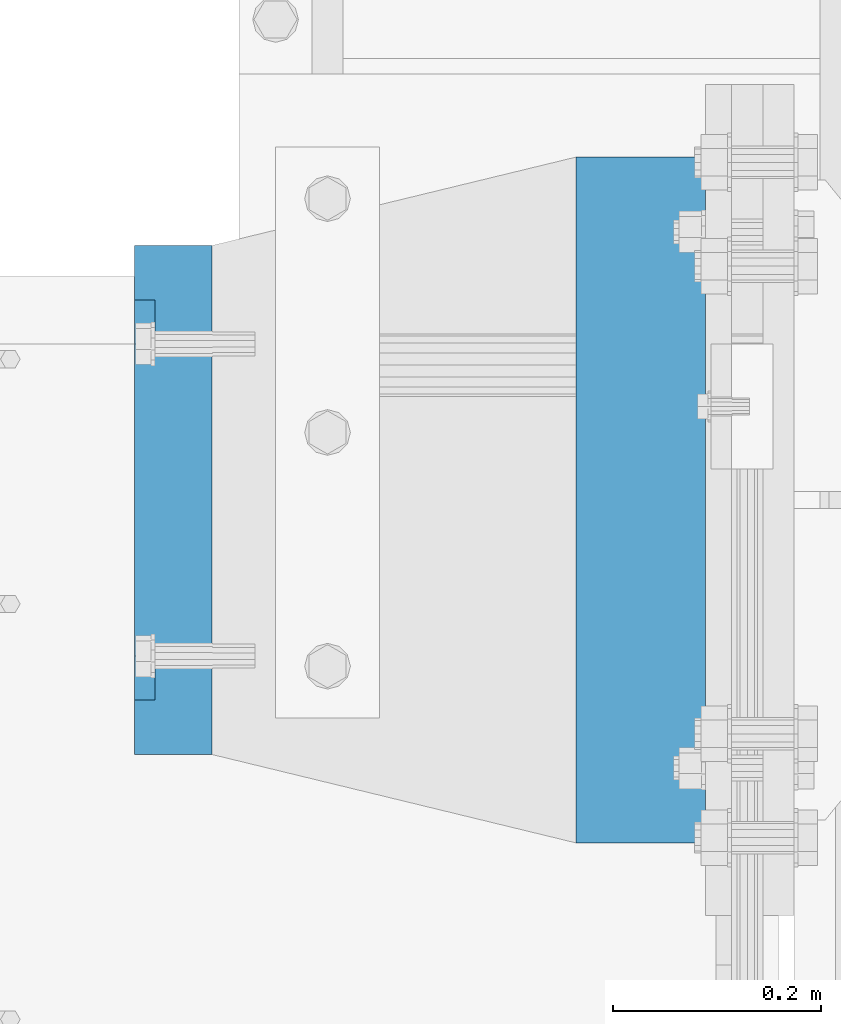
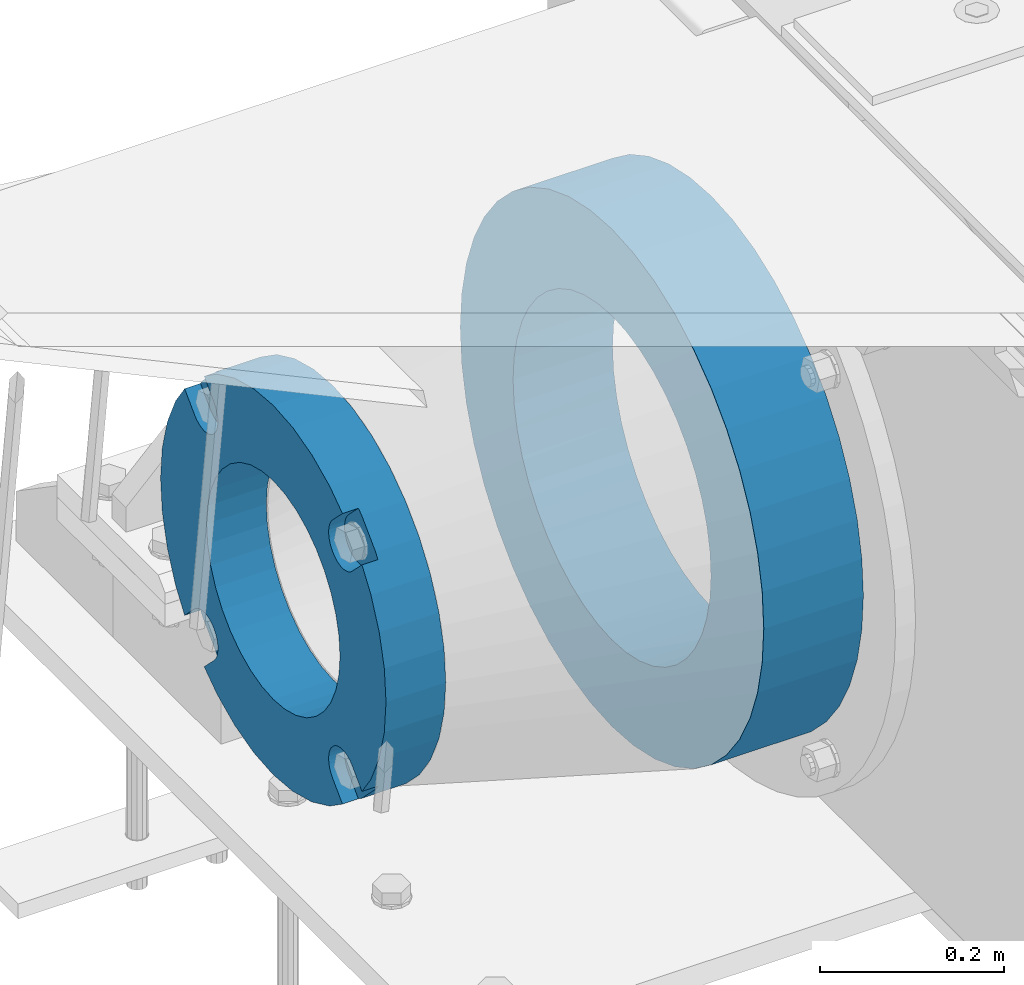
# One storey, part 147 of 247: 2 beams.
"""IFC2X3 building model written with IfcOpenShell, lengths in millimetres."""

from ifc_helpers import new_model, si_unit, frame, origin_with_axes, place, context, subcontext, project, spatial, faceted_brep, material, type_object, element, save


model = new_model("IFC2X3")

# Units and contexts
model_context = context("Model", 3, precision=1e-05, world=origin_with_axes())
body_context = subcontext(model_context, "Body", "Model", "MODEL_VIEW")
ifc_project = project(units=[si_unit("LENGTHUNIT", "METRE", prefix="MILLI"), si_unit("AREAUNIT", "SQUARE_METRE"), si_unit("VOLUMEUNIT", "CUBIC_METRE"), si_unit("MASSUNIT", "GRAM", prefix="KILO"), si_unit("TIMEUNIT", "SECOND"), si_unit("PLANEANGLEUNIT", "RADIAN"), si_unit("SOLIDANGLEUNIT", "STERADIAN"), si_unit("THERMODYNAMICTEMPERATUREUNIT", "DEGREE_CELSIUS"), si_unit("LUMINOUSINTENSITYUNIT", "LUMEN")], contexts=[model_context])

# Site, building, storey
site_placement = place(None, origin_with_axes())
site = spatial("IfcSite", under=ifc_project, at=site_placement, CompositionType="ELEMENT")
building_placement = place(site_placement, origin_with_axes())
building = spatial("IfcBuilding", under=site, at=building_placement, Name="Standard", CompositionType="ELEMENT")
storey_placement = place(building_placement, origin_with_axes())
storey = spatial("IfcBuildingStorey", under=building, at=storey_placement, Name="Undefined", CompositionType="ELEMENT", Elevation=0.0)

# Beams
ifc_material_1 = material(Name="SCN-500-E2")
beam_type_1 = type_object("IfcBeamType", PredefinedType="NOTDEFINED")
beam_1_placement = place(storey_placement, frame((-550.0, 9000.00000146624, -515.0), z_axis=(0.0, 0.0, 1.0), x_axis=(-1.0, 0.0, 0.0)))
element("IfcBeam", 1, at=beam_1_placement, inside=storey, type_object=beam_type_1, material=ifc_material_1, context=body_context, shape_type="Brep", body=[
    faceted_brep([(75.0, 192.717024793295, -150.290616455866), (75.0, 171.473395903973, -129.046987566544), (55.0000000000002, 171.473395903973, -129.046987566544), (55.0000000000002, 192.717024793295, -150.290616455866), (75.0, 167.467485558764, -125.68562967346), (55.0000000000002, 167.467485558764, -125.68562967346), (75.0, 162.938740320458, -123.070957391021), (55.0000000000002, 162.938740320458, -123.070957391021), (75.0, 158.024763821319, -121.282416213441), (55.0000000000002, 158.024763821319, -121.282416213441), (75.0, 152.874864750675, -120.374350059354), (55.0000000000002, 152.874864750675, -120.374350059354), (75.0, 147.645520185815, -120.374350059348), (55.0000000000002, 147.645520185815, -120.374350059348), (75.0, 142.495621115171, -121.282416213423), (55.0000000000002, 142.495621115171, -121.282416213423), (75.0, 137.581644616022, -123.070957390992), (55.0000000000002, 137.581644616022, -123.070957390992), (75.0, 133.052899377708, -125.68562967342), (55.0000000000002, 133.052899377708, -125.68562967342), (75.0, 129.04698903278, -129.046987566545), (55.0000000000002, 129.04698903278, -129.046987566545), (75.0, 125.685631139648, -133.052897911627), (55.0000000000002, 125.685631139648, -133.052897911627), (75.0, 123.070958857221, -137.581643149937), (55.0000000000002, 123.070958857221, -137.581643149937), (75.0, 121.282417679651, -142.495619649082), (55.0000000000002, 121.282417679651, -142.495619649082), (75.0, 120.374351525574, -147.64551871973), (55.0000000000002, 120.374351525574, -147.64551871973), (75.0, 120.374351525579, -152.874863284592), (55.0000000000002, 120.374351525579, -152.874863284592), (75.0, 121.282417679666, -158.024762355239), (55.0000000000002, 121.282417679666, -158.024762355239), (75.0, 123.070958857244, -162.938738854385), (55.0000000000002, 123.070958857244, -162.938738854385), (75.0, 125.68563113968, -167.467484092695), (55.0000000000002, 125.68563113968, -167.467484092695), (75.0, 129.04698903278, -171.473394437738), (55.0000000000002, 129.04698903278, -171.473394437738), (55.0000000000002, 150.290618180639, -192.717023585596), (75.0, 150.290618180639, -192.717023585596), (55.0000000000002, 157.482964373203, -187.68088856415), (55.0000000000002, 187.680888564149, -157.482964373202), (75.0, -192.717023585596, 150.290618180639), (75.0, -171.4733929715, 129.046987566544), (55.0000000000002, -171.4733929715, 129.046987566544), (55.0000000000002, -192.717023585596, 150.290618180639), (75.0, -167.467482626291, 125.685629673459), (55.0000000000002, -167.467482626291, 125.685629673459), (75.0, -162.938737387985, 123.070957391021), (55.0000000000002, -162.938737387985, 123.070957391021), (75.0, -158.024760888846, 121.28241621344), (55.0000000000002, -158.024760888846, 121.28241621344), (75.0, -152.874861818202, 120.374350059353), (55.0000000000002, -152.874861818202, 120.374350059353), (75.0, -147.645517253342, 120.374350059347), (55.0000000000002, -147.645517253342, 120.374350059347), (75.0, -142.495618182698, 121.282416213422), (55.0000000000002, -142.495618182698, 121.282416213422), (75.0, -137.58164168355, 123.070957390991), (55.0000000000002, -137.58164168355, 123.070957390991), (75.0, -133.052896445235, 125.685629673419), (55.0000000000002, -133.052896445235, 125.685629673419), (75.0, -129.046986100308, 129.046987566544), (55.0000000000002, -129.046986100308, 129.046987566544), (75.0, -125.685628207175, 133.052897911626), (55.0000000000002, -125.685628207175, 133.052897911626), (75.0, -123.070955924748, 137.581643149936), (55.0000000000002, -123.070955924748, 137.581643149936), (75.0, -121.282414747178, 142.495619649081), (55.0000000000002, -121.282414747178, 142.495619649081), (75.0, -120.374348593101, 147.645518719729), (55.0000000000002, -120.374348593101, 147.645518719729), (75.0, -120.374348593106, 152.874863284591), (55.0000000000002, -120.374348593106, 152.874863284591), (75.0, -121.282414747193, 158.024762355238), (55.0000000000002, -121.282414747193, 158.024762355238), (75.0, -123.070955924772, 162.938738854384), (55.0000000000002, -123.070955924772, 162.938738854384), (75.0, -125.685628207208, 167.467484092694), (55.0000000000002, -125.685628207208, 167.467484092694), (75.0, -129.046986100308, 171.473394437737), (55.0000000000002, -129.046986100308, 171.473394437737), (55.0000000000002, -150.290616455866, 192.717024793295), (75.0, -150.290616455866, 192.717024793295), (75.0, 150.290618180639, 192.717023585597), (75.0000000000001, 129.04698903278, 171.473394437739), (55.0000000000002, 129.04698903278, 171.473394437739), (55.0000000000002, 150.290618180637, 192.717023585597), (75.0000000000001, 125.685631139695, 167.46748409253), (55.0000000000002, 125.685631139695, 167.46748409253), (75.0000000000001, 123.070958857257, 162.938738854225), (55.0000000000002, 123.070958857257, 162.938738854225), (75.0000000000001, 121.282417679677, 158.024762355085), (55.0000000000002, 121.282417679677, 158.024762355085), (75.0000000000001, 120.37435152559, 152.874863284441), (55.0000000000002, 120.37435152559, 152.874863284441), (75.0000000000001, 120.374351525585, 147.645518719582), (55.0000000000002, 120.374351525585, 147.645518719582), (75.0000000000001, 121.282417679658, 142.495619648937), (55.0000000000002, 121.282417679658, 142.495619648937), (75.0000000000001, 123.070958857228, 137.581643149788), (55.0000000000002, 123.070958857228, 137.581643149788), (75.0000000000001, 125.685631139655, 133.052897911475), (55.0000000000002, 125.685631139655, 133.052897911475), (75.0000000000001, 129.04698903278, 129.046987566546), (55.0000000000002, 129.04698903278, 129.046987566546), (75.0000000000001, 133.052899377863, 125.685629673414), (55.0000000000002, 133.052899377863, 125.685629673414), (75.0000000000001, 137.581644616172, 123.070957390986), (55.0000000000002, 137.581644616172, 123.070957390986), (75.0000000000001, 142.495621115319, 121.282416213417), (55.0000000000002, 142.495621115319, 121.282416213417), (75.0000000000001, 147.645520185966, 120.37435005934), (55.0000000000002, 147.645520185966, 120.37435005934), (75.0000000000001, 152.874864750827, 120.374350059345), (55.0000000000002, 152.874864750827, 120.374350059345), (75.0000000000001, 158.024763821475, 121.282416213431), (55.0000000000002, 158.024763821475, 121.282416213431), (75.0000000000001, 162.93874032062, 123.07095739101), (55.0000000000002, 162.93874032062, 123.07095739101), (75.0000000000001, 167.467485558931, 125.685629673446), (55.0000000000002, 167.467485558931, 125.685629673446), (75.0000000000001, 171.473395903973, 129.046987566546), (55.0000000000002, 171.473395903973, 129.046987566546), (55.0000000000002, 192.717024793294, 150.290616455867), (75.0, 192.717024793294, 150.290616455867), (0.0, 212.176223927188, -122.5), (0.0, 230.224692092548, -83.7949351147888), (75.0, 230.224692092548, -83.7949351147888), (75.0, 212.176223927188, -122.5), (0.0, 241.277899487992, -42.5438035283978), (75.0, 241.277899487992, -42.5438035283978), (0.0, 245.0, 0.0), (75.0, 245.0, 0.0), (0.0, 241.277899487992, 42.543803528398), (75.0, 241.277899487992, 42.543803528398), (0.0, 230.224692092548, 83.7949351147889), (75.0, 230.224692092548, 83.7949351147889), (0.0, 212.176223927188, 122.5), (75.0, 212.176223927188, 122.5), (0.0, 187.680888564149, 157.482964373202), (55.0000000000002, 187.680888564149, 157.482964373202), (0.0, 157.482964373203, 187.68088856415), (55.0000000000002, 157.482964373203, 187.68088856415), (0.0, 122.5, 212.176223927187), (75.0, 122.5, 212.176223927187), (0.0, 83.794935114789, 230.224692092548), (75.0, 83.794935114789, 230.224692092548), (0.0, 42.5438035283987, 241.277899487991), (75.0, 42.5438035283987, 241.277899487991), (0.0, 0.0, 245.0), (75.0, 0.0, 245.0), (0.0, -42.5438035283987, 241.277899487991), (75.0, -42.5438035283987, 241.277899487991), (0.0, -83.794935114789, 230.224692092548), (75.0, -83.794935114789, 230.224692092548), (0.0, -122.5, 212.176223927187), (75.0, -122.5, 212.176223927187), (0.0, -157.482964373203, 187.68088856415), (55.0000000000002, -157.482964373203, 187.68088856415), (0.0, -187.680888564149, 157.482964373202), (55.0000000000002, -187.680888564149, 157.482964373202), (0.0, -212.176223927188, 122.5), (75.0, -212.176223927188, 122.5), (0.0, -230.224692092548, 83.7949351147888), (75.0, -230.224692092548, 83.7949351147888), (0.0, -241.277899487992, 42.5438035283979), (75.0, -241.277899487992, 42.5438035283979), (0.0, -245.0, 0.0), (75.0, -245.0, 0.0), (0.0, -187.680888564149, -157.482964373202), (0.0, -157.482964373203, -187.68088856415), (55.0000000000002, -157.482964373203, -187.68088856415), (55.0000000000002, -187.680888564149, -157.482964373202), (0.0, 83.794935114789, -230.224692092547), (0.0, 122.5, -212.176223927187), (75.0, 122.5, -212.176223927187), (75.0, 83.794935114789, -230.224692092547), (0.0, 42.5438035283987, -241.277899487991), (75.0, 42.5438035283987, -241.277899487991), (0.0, 0.0, -245.0), (75.0, 0.0, -245.0), (0.0, -42.5438035283987, -241.277899487991), (75.0, -42.5438035283987, -241.277899487991), (0.0, -83.794935114789, -230.224692092548), (75.0, -83.794935114789, -230.224692092548), (0.0, -122.5, -212.176223927187), (75.0, -122.5, -212.176223927187), (75.0, -150.290616455864, -192.717024793297), (55.0000000000002, -150.290616455864, -192.717024793296), (55.0000000000002, -129.046986100308, -171.47339443774), (55.0000000000002, -125.685628207224, -167.46748409253), (55.0000000000002, -123.070955924784, -162.938738854225), (55.0000000000002, -121.282414747204, -158.024762355085), (55.0000000000002, -120.374348593117, -152.874863284441), (55.0000000000002, -120.374348593112, -147.645518719582), (55.0000000000002, -121.282414747186, -142.495619648937), (55.0000000000002, -123.070955924755, -137.581643149788), (55.0000000000002, -125.685628207182, -133.052897911475), (55.0000000000002, -129.046986100308, -129.046987566547), (55.0000000000002, -133.05289644539, -125.685629673414), (55.0000000000002, -137.581641683699, -123.070957390986), (55.0000000000002, -142.495618182846, -121.282416213417), (55.0000000000002, -147.645517253493, -120.37435005934), (55.0000000000002, -152.874861818354, -120.374350059345), (55.0000000000002, -158.024760889002, -121.282416213431), (55.0000000000002, -162.938737388147, -123.07095739101), (55.0000000000002, -167.467482626458, -125.685629673446), (55.0000000000002, -171.4733929715, -129.046987566546), (55.0000000000002, -192.717023585594, -150.29061818064), (75.0, -129.046986100308, -171.47339443774), (75.0, -125.685628207224, -167.46748409253), (75.0, -123.070955924784, -162.938738854225), (75.0, -121.282414747204, -158.024762355085), (75.0, -120.374348593117, -152.874863284441), (75.0, -120.374348593112, -147.645518719582), (75.0, -121.282414747186, -142.495619648937), (75.0, -123.070955924755, -137.581643149788), (75.0, -125.685628207182, -133.052897911475), (75.0, -129.046986100308, -129.046987566547), (75.0, -133.05289644539, -125.685629673414), (75.0, -137.581641683699, -123.070957390986), (75.0, -142.495618182846, -121.282416213417), (75.0, -147.645517253493, -120.37435005934), (75.0, -152.874861818354, -120.374350059345), (75.0, -158.024760889002, -121.282416213431), (75.0, -162.938737388147, -123.07095739101), (75.0, -167.467482626458, -125.685629673446), (75.0, -171.4733929715, -129.046987566546), (75.0, -192.717023585596, -150.290618180641), (75.0, -212.176223927187, -122.5), (0.0, -212.176223927187, -122.5), (0.0, -230.224692092548, -83.794935114789), (75.0, -230.224692092548, -83.794935114789), (0.0, -241.277899487992, -42.5438035283979), (75.0, -241.277899487992, -42.5438035283979), (0.0, 187.680888564149, -157.482964373202), (0.0, 157.482964373203, -187.68088856415), (0.0, -142.797124186771, -25.1789857617049), (0.0, -136.255430013956, -49.592920782222), (0.0, -125.573683548744, -72.5), (0.0, -111.076444252252, -93.2042034045483), (0.0, -93.204203404548, -111.076444252252), (0.0, -72.5, -125.573683548744), (0.0, -49.5929207822228, -136.255430013957), (0.0, -25.1789857617041, -142.79712418677), (0.0, 0.0, -145.0), (0.0, 25.1789857617041, -142.79712418677), (0.0, 49.5929207822228, -136.255430013957), (0.0, 72.5, -125.573683548744), (0.0, 93.204203404548, -111.076444252252), (0.0, 111.076444252252, -93.2042034045483), (0.0, 125.573683548744, -72.5), (0.0, 136.255430013956, -49.592920782222), (0.0, 142.797124186771, -25.178985761705), (0.0, 145.0, 0.0), (0.0, 142.797124186771, 25.1789857617048), (0.0, 136.255430013956, 49.5929207822219), (0.0, 125.573683548744, 72.4999999999999), (0.0, 111.076444252252, 93.2042034045482), (0.0, 93.204203404548, 111.076444252252), (0.0, 72.5, 125.573683548744), (0.0, 49.5929207822228, 136.255430013957), (0.0, 25.1789857617041, 142.79712418677), (0.0, 0.0, 145.0), (0.0, -25.1789857617041, 142.79712418677), (0.0, -49.5929207822228, 136.255430013957), (0.0, -72.5, 125.573683548744), (0.0, -93.204203404548, 111.076444252252), (0.0, -111.076444252252, 93.2042034045483), (0.0, -125.573683548744, 72.5000000000001), (0.0, -136.255430013956, 49.5929207822221), (0.0, -142.797124186771, 25.1789857617049), (0.0, -145.0, 0.0), (75.0, -145.0, 0.0), (75.0, -142.797124186771, -25.1789857617049), (75.0, -136.255430013956, -49.592920782222), (75.0, -125.573683548744, -72.5), (75.0, -111.076444252252, -93.2042034045483), (75.0, -93.204203404548, -111.076444252252), (75.0, -72.5, -125.573683548744), (75.0, -49.5929207822228, -136.255430013957), (75.0, -25.1789857617041, -142.79712418677), (75.0, 0.0, -145.0), (75.0, 25.1789857617041, -142.79712418677), (75.0, 49.5929207822228, -136.255430013957), (75.0, 72.5, -125.573683548744), (75.0, 93.204203404548, -111.076444252252), (75.0, 111.076444252252, -93.2042034045483), (75.0, 125.573683548744, -72.5), (75.0, 136.255430013956, -49.592920782222), (75.0, 142.797124186771, -25.178985761705), (75.0, 145.0, 0.0), (75.0, 142.797124186771, 25.1789857617048), (75.0, 136.255430013956, 49.5929207822219), (75.0, 125.573683548744, 72.4999999999999), (75.0, 111.076444252252, 93.2042034045482), (75.0, 93.204203404548, 111.076444252252), (75.0, 72.5, 125.573683548744), (75.0, 49.5929207822228, 136.255430013957), (75.0, 25.1789857617041, 142.79712418677), (75.0, 0.0, 145.0), (75.0, -25.1789857617041, 142.79712418677), (75.0, -49.5929207822228, 136.255430013957), (75.0, -72.5, 125.573683548744), (75.0, -93.204203404548, 111.076444252252), (75.0, -111.076444252252, 93.2042034045483), (75.0, -125.573683548744, 72.5000000000001), (75.0, -136.255430013956, 49.5929207822221), (75.0, -142.797124186771, 25.1789857617049)], [[[0, 1, 2, 3]], [[4, 5, 2, 1]], [[6, 7, 5, 4]], [[8, 9, 7, 6]], [[10, 11, 9, 8]], [[12, 13, 11, 10]], [[14, 15, 13, 12]], [[16, 17, 15, 14]], [[18, 19, 17, 16]], [[20, 21, 19, 18]], [[22, 23, 21, 20]], [[24, 25, 23, 22]], [[26, 27, 25, 24]], [[28, 29, 27, 26]], [[30, 31, 29, 28]], [[32, 33, 31, 30]], [[34, 35, 33, 32]], [[36, 37, 35, 34]], [[38, 39, 37, 36]], [[40, 39, 38, 41]], [[42, 43, 3, 2, 5, 7, 9, 11, 13, 15, 17, 19, 21, 23, 25, 27, 29, 31, 33, 35, 37, 39, 40]], [[44, 45, 46, 47]], [[48, 49, 46, 45]], [[50, 51, 49, 48]], [[52, 53, 51, 50]], [[54, 55, 53, 52]], [[56, 57, 55, 54]], [[58, 59, 57, 56]], [[60, 61, 59, 58]], [[62, 63, 61, 60]], [[64, 65, 63, 62]], [[66, 67, 65, 64]], [[68, 69, 67, 66]], [[70, 71, 69, 68]], [[72, 73, 71, 70]], [[74, 75, 73, 72]], [[76, 77, 75, 74]], [[78, 79, 77, 76]], [[80, 81, 79, 78]], [[82, 83, 81, 80]], [[84, 83, 82, 85]], [[86, 87, 88, 89]], [[90, 91, 88, 87]], [[92, 93, 91, 90]], [[94, 95, 93, 92]], [[96, 97, 95, 94]], [[98, 99, 97, 96]], [[100, 101, 99, 98]], [[102, 103, 101, 100]], [[104, 105, 103, 102]], [[106, 107, 105, 104]], [[108, 109, 107, 106]], [[110, 111, 109, 108]], [[112, 113, 111, 110]], [[114, 115, 113, 112]], [[116, 117, 115, 114]], [[118, 119, 117, 116]], [[120, 121, 119, 118]], [[122, 123, 121, 120]], [[124, 125, 123, 122]], [[126, 125, 124, 127]], [[128, 129, 130, 131]], [[129, 132, 133, 130]], [[132, 134, 135, 133]], [[134, 136, 137, 135]], [[136, 138, 139, 137]], [[138, 140, 141, 139]], [[127, 141, 140, 142, 143, 126]], [[142, 144, 145, 143]], [[89, 88, 91, 93, 95, 97, 99, 101, 103, 105, 107, 109, 111, 113, 115, 117, 119, 121, 123, 125, 126, 143, 145]], [[144, 146, 147, 86, 89, 145]], [[146, 148, 149, 147]], [[148, 150, 151, 149]], [[150, 152, 153, 151]], [[152, 154, 155, 153]], [[154, 156, 157, 155]], [[156, 158, 159, 157]], [[85, 159, 158, 160, 161, 84]], [[160, 162, 163, 161]], [[47, 46, 49, 51, 53, 55, 57, 59, 61, 63, 65, 67, 69, 71, 73, 75, 77, 79, 81, 83, 84, 161, 163]], [[162, 164, 165, 44, 47, 163]], [[164, 166, 167, 165]], [[166, 168, 169, 167]], [[168, 170, 171, 169]], [[172, 173, 174, 175]], [[176, 177, 178, 179]], [[180, 176, 179, 181]], [[182, 180, 181, 183]], [[184, 182, 183, 185]], [[186, 184, 185, 187]], [[188, 186, 187, 189]], [[173, 188, 189, 190, 191, 174]], [[175, 174, 191, 192, 193, 194, 195, 196, 197, 198, 199, 200, 201, 202, 203, 204, 205, 206, 207, 208, 209, 210, 211]], [[190, 212, 192, 191]], [[213, 193, 192, 212]], [[214, 194, 193, 213]], [[215, 195, 194, 214]], [[216, 196, 195, 215]], [[217, 197, 196, 216]], [[218, 198, 197, 217]], [[219, 199, 198, 218]], [[220, 200, 199, 219]], [[221, 201, 200, 220]], [[222, 202, 201, 221]], [[223, 203, 202, 222]], [[224, 204, 203, 223]], [[225, 205, 204, 224]], [[226, 206, 205, 225]], [[227, 207, 206, 226]], [[228, 208, 207, 227]], [[229, 209, 208, 228]], [[230, 210, 209, 229]], [[211, 210, 230, 231]], [[232, 233, 172, 175, 211, 231]], [[234, 233, 232, 235]], [[236, 234, 235, 237]], [[170, 236, 237, 171]], [[168, 166, 164, 162, 160, 158, 156, 154, 152, 150, 148, 146, 144, 142, 140, 138, 136, 134, 132, 129, 128, 238, 239, 177, 176, 180, 182, 184, 186, 188, 173, 172, 233, 234, 236, 170], [240, 241, 242, 243, 244, 245, 246, 247, 248, 249, 250, 251, 252, 253, 254, 255, 256, 257, 258, 259, 260, 261, 262, 263, 264, 265, 266, 267, 268, 269, 270, 271, 272, 273, 274, 275]], [[240, 275, 276, 277]], [[241, 240, 277, 278]], [[242, 241, 278, 279]], [[243, 242, 279, 280]], [[244, 243, 280, 281]], [[245, 244, 281, 282]], [[246, 245, 282, 283]], [[247, 246, 283, 284]], [[248, 247, 284, 285]], [[249, 248, 285, 286]], [[250, 249, 286, 287]], [[251, 250, 287, 288]], [[252, 251, 288, 289]], [[253, 252, 289, 290]], [[254, 253, 290, 291]], [[255, 254, 291, 292]], [[256, 255, 292, 293]], [[257, 256, 293, 294]], [[258, 257, 294, 295]], [[259, 258, 295, 296]], [[260, 259, 296, 297]], [[261, 260, 297, 298]], [[262, 261, 298, 299]], [[263, 262, 299, 300]], [[264, 263, 300, 301]], [[265, 264, 301, 302]], [[266, 265, 302, 303]], [[267, 266, 303, 304]], [[268, 267, 304, 305]], [[269, 268, 305, 306]], [[270, 269, 306, 307]], [[271, 270, 307, 308]], [[272, 271, 308, 309]], [[273, 272, 309, 310]], [[274, 273, 310, 311]], [[275, 274, 311, 276]], [[24, 22, 20, 18, 16, 14, 12, 10, 8, 6, 4, 1, 0, 131, 130, 133, 135, 137, 139, 141, 127, 124, 122, 120, 118, 116, 114, 112, 110, 108, 106, 104, 102, 100, 98, 96, 94, 92, 90, 87, 86, 147, 149, 151, 153, 155, 157, 159, 85, 82, 80, 78, 76, 74, 72, 70, 68, 66, 64, 62, 60, 58, 56, 54, 52, 50, 48, 45, 44, 165, 167, 169, 171, 237, 235, 232, 231, 230, 229, 228, 227, 226, 225, 224, 223, 222, 221, 220, 219, 218, 217, 216, 215, 214, 213, 212, 190, 189, 187, 185, 183, 181, 179, 178, 41, 38, 36, 34, 32, 30, 28, 26], [310, 309, 308, 307, 306, 305, 304, 303, 302, 301, 300, 299, 298, 297, 296, 295, 294, 293, 292, 291, 290, 289, 288, 287, 286, 285, 284, 283, 282, 281, 280, 279, 278, 277, 276, 311]], [[238, 128, 131, 0, 3, 43]], [[239, 238, 43, 42]], [[178, 177, 239, 42, 40, 41]]]),
])
ifc_material_2 = material(Name="STEEL/S355N")
beam_type_2 = type_object("IfcBeamType", PredefinedType="NOTDEFINED")
beam_2_placement = place(storey_placement, frame((-74.999999999991, 9000.0, -515.0), z_axis=(0.0, 0.0, 1.0), x_axis=(-1.0, 0.0, 0.0)))
element("IfcBeam", 2, at=beam_2_placement, inside=storey, type_object=beam_type_2, material=ifc_material_2, context=body_context, shape_type="Brep", body=[
    faceted_brep([(0.0, -215.0, 0.0), (0.0, -212.811610004401, 30.5976902287563), (125.0, -212.811610004401, 30.5976902287563), (125.0, -215.0, 0.0), (0.0, -206.290989327117, 60.5724997209074), (125.0, -206.290989327117, 60.5724997209074), (0.0, -195.570879001221, 89.3142277954056), (125.0, -195.570879001221, 89.3142277954056), (0.0, -180.869509558705, 116.237775752953), (125.0, -180.869509558705, 116.237775752953), (0.0, -162.486158486165, 140.795057798236), (125.0, -162.486158486165, 140.795057798236), (0.0, -140.795057798236, 162.486158486165), (125.0, -140.795057798236, 162.486158486165), (0.0, -116.237775752954, 180.869509558704), (125.0, -116.237775752954, 180.869509558704), (0.0, -89.3142277954048, 195.570879001222), (125.0, -89.3142277954048, 195.570879001222), (0.0, -60.5724997209072, 206.290989327117), (125.0, -60.5724997209072, 206.290989327117), (0.0, -30.5976902287566, 212.811610004401), (125.0, -30.5976902287566, 212.811610004401), (0.0, 0.0, 215.0), (125.0, 0.0, 215.0), (0.0, 30.5976902287566, 212.811610004401), (125.0, 30.5976902287566, 212.811610004401), (0.0, 60.5724997209072, 206.290989327117), (125.0, 60.5724997209072, 206.290989327117), (0.0, 89.3142277954048, 195.570879001221), (125.0, 89.3142277954048, 195.570879001221), (0.0, 116.237775752954, 180.869509558704), (125.0, 116.237775752954, 180.869509558704), (0.0, 140.795057798236, 162.486158486165), (125.0, 140.795057798236, 162.486158486165), (0.0, 162.486158486165, 140.795057798236), (125.0, 162.486158486165, 140.795057798236), (0.0, 180.869509558705, 116.237775752953), (125.0, 180.869509558705, 116.237775752953), (0.0, 195.570879001221, 89.3142277954056), (125.0, 195.570879001221, 89.3142277954056), (0.0, 206.290989327117, 60.5724997209073), (125.0, 206.290989327117, 60.5724997209073), (0.0, 212.811610004401, 30.5976902287563), (125.0, 212.811610004401, 30.5976902287563), (0.0, 215.0, 0.0), (125.0, 215.0, 0.0), (0.0, 212.811610004401, -30.5976902287563), (125.0, 212.811610004401, -30.5976902287563), (0.0, 206.290989327117, -60.5724997209073), (125.0, 206.290989327117, -60.5724997209073), (0.0, 195.570879001221, -89.3142277954056), (125.0, 195.570879001221, -89.3142277954056), (0.0, 180.869509558705, -116.237775752954), (125.0, 180.869509558705, -116.237775752954), (0.0, 162.486158486165, -140.795057798236), (125.0, 162.486158486165, -140.795057798236), (0.0, 140.795057798236, -162.486158486166), (125.0, 140.795057798236, -162.486158486166), (0.0, 116.237775752954, -180.869509558704), (125.0, 116.237775752954, -180.869509558704), (0.0, 89.3142277954048, -195.570879001221), (125.0, 89.3142277954048, -195.570879001221), (0.0, 60.5724997209072, -206.290989327117), (125.0, 60.5724997209072, -206.290989327117), (0.0, 30.5976902287566, -212.811610004401), (125.0, 30.5976902287566, -212.811610004401), (0.0, 0.0, -215.0), (125.0, 0.0, -215.0), (0.0, -30.5976902287566, -212.811610004401), (125.0, -30.5976902287566, -212.811610004401), (0.0, -60.5724997209072, -206.290989327117), (125.0, -60.5724997209072, -206.290989327117), (0.0, -89.3142277954048, -195.570879001221), (125.0, -89.3142277954048, -195.570879001221), (0.0, -116.237775752954, -180.869509558704), (125.0, -116.237775752954, -180.869509558704), (0.0, -140.795057798236, -162.486158486166), (125.0, -140.795057798236, -162.486158486166), (0.0, -162.486158486165, -140.795057798236), (125.0, -162.486158486165, -140.795057798236), (0.0, -180.869509558705, -116.237775752953), (125.0, -180.869509558705, -116.237775752953), (0.0, -195.570879001221, -89.3142277954056), (125.0, -195.570879001221, -89.3142277954056), (0.0, -206.290989327117, -60.5724997209073), (125.0, -206.290989327117, -60.5724997209073), (0.0, -212.811610004401, -30.5976902287563), (125.0, -212.811610004401, -30.5976902287563), (0.0, -330.0, 0.0), (0.0, -326.641075820708, -46.9638966301842), (125.0, -326.641075820708, -46.9638966301842), (125.0, -330.0, 0.0), (0.0, -316.632681292784, -92.9717437576718), (125.0, -316.632681292784, -92.9717437576718), (0.0, -300.178558466991, -137.086954290623), (125.0, -300.178558466991, -137.086954290623), (0.0, -277.613665834289, -178.411469760347), (125.0, -277.613665834289, -178.411469760347), (0.0, -249.397359536906, -216.104042201944), (125.0, -249.397359536906, -216.104042201944), (0.0, -216.104042201943, -249.397359536905), (125.0, -216.104042201943, -249.397359536905), (0.0, -178.411469760347, -277.61366583429), (125.0, -178.411469760347, -277.61366583429), (0.0, -137.086954290622, -300.178558466991), (125.0, -137.086954290622, -300.178558466991), (0.0, -92.971743757671, -316.632681292784), (125.0, -92.971743757671, -316.632681292784), (0.0, -46.9638966301845, -326.641075820708), (125.0, -46.9638966301845, -326.641075820708), (0.0, 0.0, -330.0), (125.0, 0.0, -330.0), (0.0, 46.9638966301845, -326.641075820708), (125.0, 46.9638966301845, -326.641075820708), (0.0, 92.971743757671, -316.632681292784), (125.0, 92.971743757671, -316.632681292784), (0.0, 137.086954290622, -300.178558466991), (125.0, 137.086954290622, -300.178558466991), (0.0, 178.411469760347, -277.61366583429), (125.0, 178.411469760347, -277.61366583429), (0.0, 216.104042201943, -249.397359536905), (125.0, 216.104042201943, -249.397359536905), (0.0, 249.397359536906, -216.104042201944), (125.0, 249.397359536906, -216.104042201944), (0.0, 277.613665834289, -178.411469760347), (125.0, 277.613665834289, -178.411469760347), (0.0, 300.178558466991, -137.086954290623), (125.0, 300.178558466991, -137.086954290623), (0.0, 316.632681292784, -92.9717437576717), (125.0, 316.632681292784, -92.9717437576717), (0.0, 326.641075820708, -46.9638966301841), (125.0, 326.641075820708, -46.9638966301841), (0.0, 330.0, 0.0), (125.0, 330.0, 0.0), (0.0, 326.641075820708, 46.9638966301841), (125.0, 326.641075820708, 46.9638966301841), (0.0, 316.632681292784, 92.9717437576718), (125.0, 316.632681292784, 92.9717437576718), (0.0, 300.178558466991, 137.086954290622), (125.0, 300.178558466991, 137.086954290622), (0.0, 277.613665834289, 178.411469760347), (125.0, 277.613665834289, 178.411469760347), (0.0, 249.397359536904, 216.104042201944), (125.0, 249.397359536904, 216.104042201944), (0.0, 216.104042201943, 249.397359536905), (125.0, 216.104042201943, 249.397359536905), (0.0, 178.411469760347, 277.61366583429), (125.0, 178.411469760347, 277.61366583429), (0.0, 137.086954290622, 300.178558466991), (125.0, 137.086954290622, 300.178558466991), (0.0, 92.971743757671, 316.632681292784), (125.0, 92.971743757671, 316.632681292784), (0.0, 46.9638966301845, 326.641075820708), (125.0, 46.9638966301845, 326.641075820708), (0.0, 0.0, 330.0), (125.0, 0.0, 330.0), (0.0, -46.9638966301845, 326.641075820708), (125.0, -46.9638966301845, 326.641075820708), (0.0, -92.971743757671, 316.632681292784), (125.0, -92.971743757671, 316.632681292784), (0.0, -137.086954290622, 300.178558466991), (125.0, -137.086954290622, 300.178558466991), (0.0, -178.411469760347, 277.61366583429), (125.0, -178.411469760347, 277.61366583429), (0.0, -216.104042201943, 249.397359536905), (125.0, -216.104042201943, 249.397359536905), (0.0, -249.397359536906, 216.104042201944), (125.0, -249.397359536906, 216.104042201944), (0.0, -277.613665834289, 178.411469760347), (125.0, -277.613665834289, 178.411469760347), (0.0, -300.178558466991, 137.086954290623), (125.0, -300.178558466991, 137.086954290623), (0.0, -316.632681292784, 92.9717437576718), (125.0, -316.632681292784, 92.9717437576718), (0.0, -326.641075820708, 46.9638966301841), (125.0, -326.641075820708, 46.9638966301841)], [[[0, 1, 2, 3]], [[1, 4, 5, 2]], [[4, 6, 7, 5]], [[6, 8, 9, 7]], [[8, 10, 11, 9]], [[10, 12, 13, 11]], [[12, 14, 15, 13]], [[14, 16, 17, 15]], [[16, 18, 19, 17]], [[18, 20, 21, 19]], [[20, 22, 23, 21]], [[22, 24, 25, 23]], [[24, 26, 27, 25]], [[26, 28, 29, 27]], [[28, 30, 31, 29]], [[30, 32, 33, 31]], [[32, 34, 35, 33]], [[34, 36, 37, 35]], [[36, 38, 39, 37]], [[38, 40, 41, 39]], [[40, 42, 43, 41]], [[42, 44, 45, 43]], [[44, 46, 47, 45]], [[46, 48, 49, 47]], [[48, 50, 51, 49]], [[50, 52, 53, 51]], [[52, 54, 55, 53]], [[54, 56, 57, 55]], [[56, 58, 59, 57]], [[58, 60, 61, 59]], [[60, 62, 63, 61]], [[62, 64, 65, 63]], [[64, 66, 67, 65]], [[66, 68, 69, 67]], [[68, 70, 71, 69]], [[70, 72, 73, 71]], [[72, 74, 75, 73]], [[74, 76, 77, 75]], [[76, 78, 79, 77]], [[78, 80, 81, 79]], [[80, 82, 83, 81]], [[82, 84, 85, 83]], [[84, 86, 87, 85]], [[86, 0, 3, 87]], [[88, 89, 90, 91]], [[89, 92, 93, 90]], [[92, 94, 95, 93]], [[94, 96, 97, 95]], [[96, 98, 99, 97]], [[98, 100, 101, 99]], [[100, 102, 103, 101]], [[102, 104, 105, 103]], [[104, 106, 107, 105]], [[106, 108, 109, 107]], [[108, 110, 111, 109]], [[110, 112, 113, 111]], [[112, 114, 115, 113]], [[114, 116, 117, 115]], [[116, 118, 119, 117]], [[118, 120, 121, 119]], [[120, 122, 123, 121]], [[122, 124, 125, 123]], [[124, 126, 127, 125]], [[126, 128, 129, 127]], [[128, 130, 131, 129]], [[130, 132, 133, 131]], [[132, 134, 135, 133]], [[134, 136, 137, 135]], [[136, 138, 139, 137]], [[138, 140, 141, 139]], [[140, 142, 143, 141]], [[142, 144, 145, 143]], [[144, 146, 147, 145]], [[146, 148, 149, 147]], [[148, 150, 151, 149]], [[150, 152, 153, 151]], [[152, 154, 155, 153]], [[154, 156, 157, 155]], [[156, 158, 159, 157]], [[158, 160, 161, 159]], [[160, 162, 163, 161]], [[162, 164, 165, 163]], [[164, 166, 167, 165]], [[166, 168, 169, 167]], [[168, 170, 171, 169]], [[170, 172, 173, 171]], [[172, 174, 175, 173]], [[174, 88, 91, 175]], [[93, 95, 97, 99, 101, 103, 105, 107, 109, 111, 113, 115, 117, 119, 121, 123, 125, 127, 129, 131, 133, 135, 137, 139, 141, 143, 145, 147, 149, 151, 153, 155, 157, 159, 161, 163, 165, 167, 169, 171, 173, 175, 91, 90], [5, 7, 9, 11, 13, 15, 17, 19, 21, 23, 25, 27, 29, 31, 33, 35, 37, 39, 41, 43, 45, 47, 49, 51, 53, 55, 57, 59, 61, 63, 65, 67, 69, 71, 73, 75, 77, 79, 81, 83, 85, 87, 3, 2]], [[174, 172, 170, 168, 166, 164, 162, 160, 158, 156, 154, 152, 150, 148, 146, 144, 142, 140, 138, 136, 134, 132, 130, 128, 126, 124, 122, 120, 118, 116, 114, 112, 110, 108, 106, 104, 102, 100, 98, 96, 94, 92, 89, 88], [86, 84, 82, 80, 78, 76, 74, 72, 70, 68, 66, 64, 62, 60, 58, 56, 54, 52, 50, 48, 46, 44, 42, 40, 38, 36, 34, 32, 30, 28, 26, 24, 22, 20, 18, 16, 14, 12, 10, 8, 6, 4, 1, 0]]]),
])

save(model, "model.ifc")
